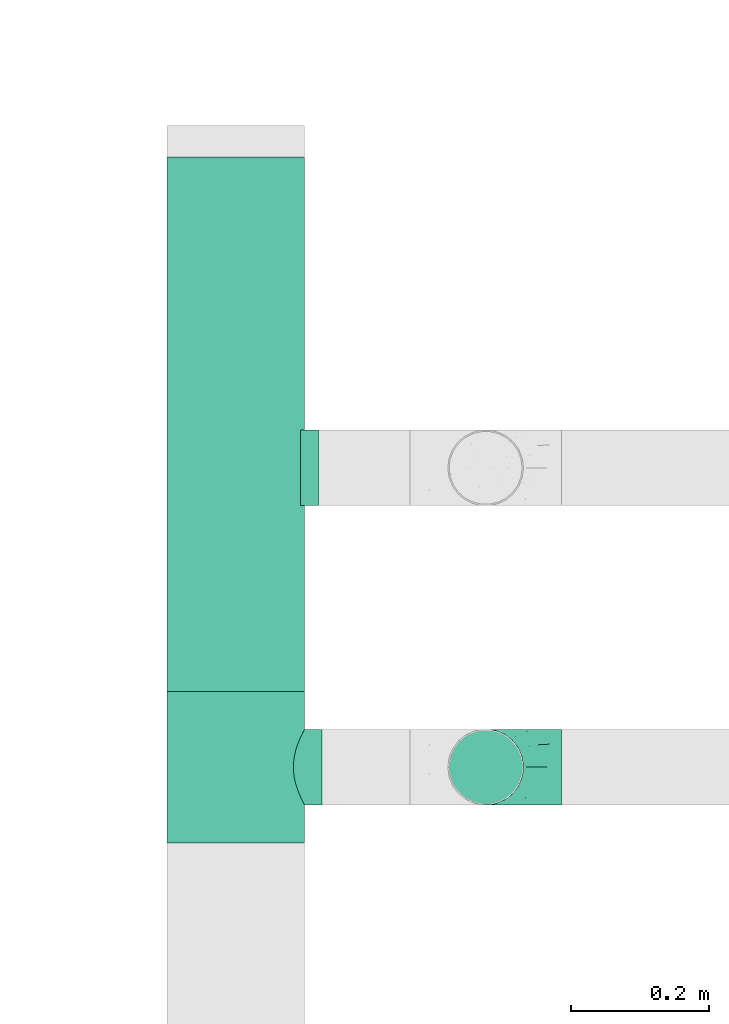
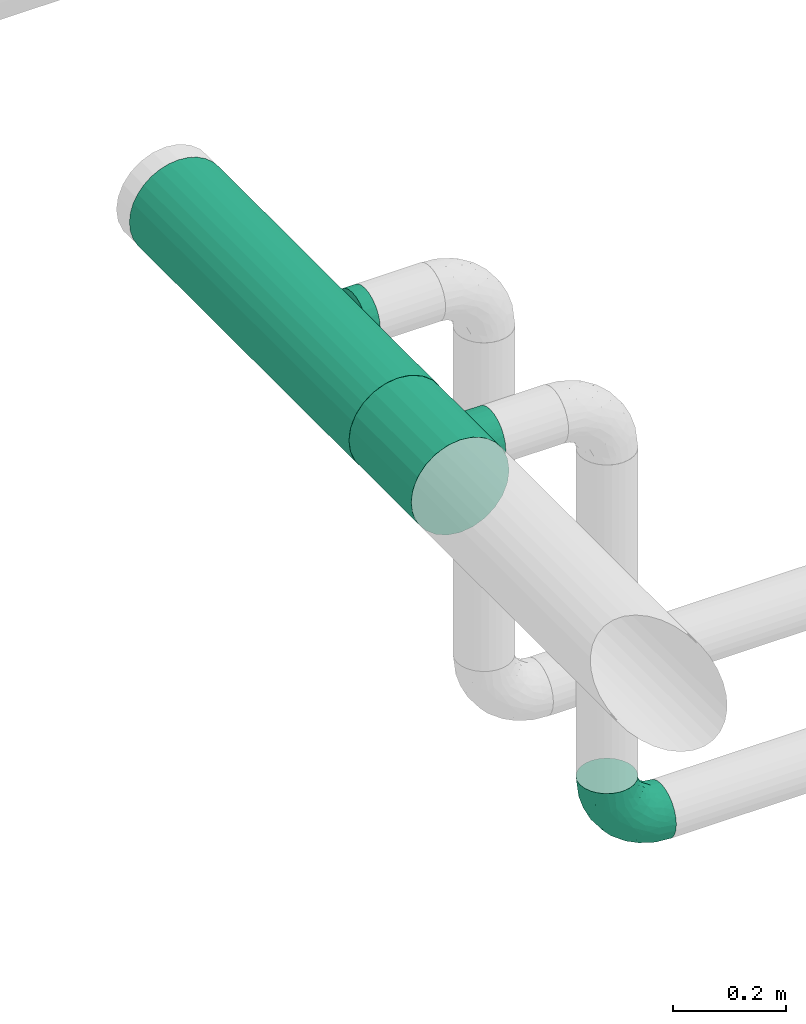
# One storey, part 68 of 91: 3 flow fittings, 1 flow segment.
"""IFC2X3 building model written with IfcOpenShell, lengths in millimetres."""

from ifc_helpers import new_model, entity, si_unit, converted_unit, derived_unit, direction, frame, origin_with_axes, origin_2d_with_axis, place, context, subcontext, project, spatial, hollow_circle, extrude, open_shell, surface_model, source, transform, mapped, material, layer, layer_set, layer_usage, type_object, element, save


model = new_model("IFC2X3")

# Units and contexts
model_context = context("Model", 3, precision=1e-05, world=origin_with_axes(), true_north=direction((0.0, 1.0)))
body_context = subcontext(model_context, "Body", "Model", "MODEL_VIEW")
ifc_project = project(units=[si_unit("AREAUNIT", "SQUARE_METRE"), si_unit("VOLUMEUNIT", "CUBIC_METRE", prefix="DECI"), si_unit("TIMEUNIT", "SECOND"), si_unit("THERMODYNAMICTEMPERATUREUNIT", "DEGREE_CELSIUS"), si_unit("PRESSUREUNIT", "PASCAL"), si_unit("MASSUNIT", "GRAM", prefix="KILO"), si_unit("LENGTHUNIT", "METRE", prefix="MILLI"), si_unit("POWERUNIT", "WATT"), si_unit("ELECTRICCURRENTUNIT", "AMPERE"), si_unit("ELECTRICVOLTAGEUNIT", "VOLT"), derived_unit("VOLUMETRICFLOWRATEUNIT", [(si_unit("VOLUMEUNIT", "CUBIC_METRE", prefix="DECI"), 1), (si_unit("TIMEUNIT", "SECOND"), -1)]), derived_unit("LINEARVELOCITYUNIT", [(si_unit("LENGTHUNIT", "METRE"), 1), (si_unit("TIMEUNIT", "SECOND"), -1)]), derived_unit("MASSDENSITYUNIT", [(si_unit("MASSUNIT", "GRAM", prefix="KILO"), 1), (si_unit("VOLUMEUNIT", "CUBIC_METRE"), -1)]), converted_unit("PLANEANGLEUNIT", "DEGREE", entity("IfcRatioMeasure", 0.01745), si_unit("PLANEANGLEUNIT", "RADIAN"), dimensions=[0, 0, 0, 0, 0, 0, 0])], contexts=[model_context])

# Site, building, storey
site_placement = place(None, origin_with_axes())
site = spatial("IfcSite", under=ifc_project, at=site_placement, CompositionType="ELEMENT")
building_placement = place(site_placement, origin_with_axes())
building = spatial("IfcBuilding", under=site, at=building_placement, Name="mc-building", CompositionType="ELEMENT")
storey_placement = place(building_placement, frame((0.0, 0.0, 8700.0), z_axis=(0.0, 0.0, 1.0), x_axis=(1.0, 0.0, 0.0)))
storey = spatial("IfcBuildingStorey", under=building, at=storey_placement, CompositionType="ELEMENT", Elevation=8700.0)

# Flow fittings
duct_fitting_type_1 = type_object("IfcDuctFittingType", Name="BU", PredefinedType="BEND")
shared_shape_1 = source(origin_with_axes(), body_context, "Body", "SurfaceModel", [
    surface_model("IfcShellBasedSurfaceModel", [(-110.0, 0.0, -55.0), (-110.0, -14.23505, -53.12592), (-110.0, 14.23505, -53.12592), (-110.0, 53.12592, 14.23505), (-110.0, 27.5, -47.63139), (-110.0, 38.89087, -38.89087), (-110.0, -55.0, 0.0), (-110.0, -53.12592, 14.23505), (-110.0, -38.89087, -38.89087), (-110.0, -27.5, -47.63139), (-110.0, -53.12592, -14.23505), (-110.0, -47.63139, -27.5), (-110.0, -14.23505, 53.12592), (-110.0, 14.23505, 53.12592), (-110.0, 27.5, 47.63139), (-110.0, -47.63139, 27.5), (-110.0, -38.89087, 38.89087), (-110.0, -27.5, 47.63139), (-110.0, 0.0, 55.0), (-110.0, 55.0, 0.0), (-110.0, 53.12592, -14.23505), (-110.0, 47.63139, -27.5), (-110.0, 47.63139, 27.5), (-110.0, 38.89087, 38.89087), (-14.23505, 110.0, -53.12592), (-55.0, 110.0, 0.0), (0.0, 110.0, -55.0), (-27.5, 110.0, -47.63139), (-38.89087, 110.0, -38.89087), (-47.63139, 110.0, -27.5), (38.89087, 110.0, -38.89087), (53.12592, 110.0, 14.23505), (27.5, 110.0, -47.63139), (14.23505, 110.0, -53.12592), (47.63139, 110.0, -27.5), (53.12592, 110.0, -14.23505), (55.0, 110.0, 0.0), (-53.12592, 110.0, -14.23505), (-53.12592, 110.0, 14.23505), (-47.63139, 110.0, 27.5), (-38.89087, 110.0, 38.89087), (-27.5, 110.0, 47.63139), (0.0, 110.0, 55.0), (-14.23505, 110.0, 53.12592), (38.89087, 110.0, 38.89087), (47.63139, 110.0, 27.5), (27.5, 110.0, 47.63139), (14.23505, 110.0, 53.12592), (-64.21732, 48.68956, 43.63444), (-76.6405, 38.18013, 45.55988), (-60.44912, 32.56953, 51.94617), (-76.00813, 5.38378, 55.0), (-90.15553, 11.94394, 54.09138), (-78.5998, 26.77405, 50.81338), (-70.18771, 18.55163, 54.03432), (-75.55424, 54.2118, 32.41257), (-93.27622, 45.77614, 33.48188), (-96.12334, 22.13664, 50.81337), (-21.00813, 45.34362, 55.0), (-18.36258, 70.48427, 54.04484), (-32.04182, 59.64019, 52.24446), (-63.88653, 74.77858, 17.99134), (-74.66383, 63.08407, 19.92123), (-63.60674, 66.07878, 29.97482), (-99.597, 52.72185, 18.52927), (-93.11138, 56.59448, 10.50359), (-98.21577, 57.34403, 0.0), (-53.42855, 92.60092, 21.04759), (-88.54852, 54.8376, 21.04759), (-11.86161, 90.23965, 54.10313), (-5.38378, 76.00813, 55.0), (-57.34403, 98.21577, 0.0), (-56.64619, 93.12774, 10.22088), (-45.34362, 21.00813, 55.0), (-44.60838, 44.60838, 52.13415), (-92.68484, 35.46673, 43.63443), (-22.25266, 95.40765, 50.81337), (-35.97783, 90.61597, 43.63443), (-43.70931, 69.58671, 44.47149), (-27.23711, 77.39884, 50.81337), (-57.2828, 79.3123, 24.9774), (-58.67786, 84.31125, 16.04456), (-82.93277, 60.36161, 12.91784), (-49.88337, 54.51816, 47.224), (-74.57753, 66.83759, 9.55742), (-45.35812, 94.97281, 33.48188), (-59.18663, 88.95241, 0.0), (-51.517, 78.6292, 33.48188), (-65.14788, 80.03077, 0.0), (-56.45322, 62.06476, 39.63545), (-88.95241, 59.18663, 0.0), (-71.10913, 71.10913, 0.0), (-80.03077, 65.14788, 0.0), (-94.9309, 45.36788, -33.48188), (-93.11358, 56.60141, -10.46614), (-99.64997, 52.79499, -18.30015), (-90.20425, 36.08686, -43.63443), (-79.99933, 46.56772, -37.92748), (-76.00813, 5.38378, -55.0), (-72.75364, 19.68651, -53.60527), (-45.34362, 21.00813, -55.0), (-21.91957, 65.12078, -53.85897), (-5.38378, 76.00813, -55.0), (-21.00813, 45.34362, -55.0), (-35.41876, 92.89265, -43.63443), (-91.10309, 11.02766, -54.21832), (-45.77614, 93.27622, -33.48188), (-90.50474, 23.21022, -50.81337), (-70.92854, 33.31794, -49.51754), (-78.52933, 63.35627, -11.73997), (-24.91508, 84.05606, -50.81337), (-88.78941, 54.74452, -21.04759), (-69.59921, 57.34866, -33.48187), (-73.36422, 62.46673, -22.94182), (-63.49062, 67.59111, -28.46929), (-56.59448, 93.11138, -10.50359), (-54.8376, 88.54852, -21.04759), (-54.10679, 75.85581, -32.31867), (-57.75956, 31.09612, -52.80882), (-52.72185, 99.597, -18.52927), (-12.62913, 89.46304, -53.99097), (-34.46825, 66.46123, -50.04329), (-43.9837, 43.9837, -52.42279), (-65.78527, 72.58348, -17.68796), (-70.34468, 43.65295, -44.21951), (-57.47001, 51.99467, -44.91465), (-60.72547, 82.29174, -12.88567), (-42.34915, 74.24548, -43.63444), (-57.25194, 63.5016, -38.08211), (-80.95344, 53.56991, -29.32027), (-52.32891, 4.55257, -54.0482), (32.52942, 47.13398, -30.48571), (14.88266, 20.92917, -33.7947), (14.95561, 36.05775, -42.26543), (30.24048, 70.09027, -41.7461), (19.3559, 65.35825, -48.00507), (-70.35075, -46.44478, -19.5952), (-47.13398, -32.52942, -30.48571), (-28.49299, -30.5778, -16.4009), (-4.55257, 52.32891, -54.0482), (-22.4954, 22.4954, -53.25347), (-75.47368, -11.22546, -52.60718), (-81.32209, -51.5606, -9.98467), (-80.81763, -41.84862, -32.14655), (-70.09027, -30.24048, -41.7461), (-36.05774, -14.95561, -42.26543), (-9.15831, -10.852, -27.8997), (-65.35825, -19.3559, -48.00507), (11.22546, 75.47368, -52.60718), (3.94376, 43.9333, -50.53315), (-13.39742, 13.39743, -48.13058), (-43.9333, -3.94376, -50.53315), (49.37776, 67.29486, 0.0), (41.8609, 47.82256, -9.92641), (50.20582, 74.51695, -9.9731), (18.93131, 11.7156, -17.56239), (-27.5, -32.89419, 0.0), (-1.23348, -12.25375, -12.18106), (41.84862, 80.81763, -32.14655), (35.70604, 41.31408, -20.38235), (46.44478, 70.35075, -19.5952), (32.89419, 27.5, 0.0), (6.67262, -6.67262, 0.0), (-67.29486, -49.37776, 0.0), (-50.36265, -42.95545, -9.51562), (-5.47251, 5.47251, -39.92906), (-70.35075, -46.44478, 19.5952), (-74.51695, -50.20582, 9.9731), (-41.31407, -35.70604, 20.38235), (-47.13398, -32.52942, 30.48571), (-80.81763, -41.84862, 32.14655), (-4.55257, 52.32891, 54.0482), (11.22546, 75.47368, 52.60718), (-43.9333, -3.94376, 50.53315), (-65.35825, -19.3559, 48.00507), (-36.05774, -14.95561, 42.26543), (-70.09027, -30.24048, 41.7461), (-11.7156, -18.93131, 17.56239), (30.5778, 28.49299, 16.4009), (12.25375, 1.23348, 12.18106), (51.5606, 81.32209, 9.98467), (42.95545, 50.36265, 9.51562), (-75.47368, -11.22546, 52.60718), (-52.32891, 4.55257, 54.0482), (3.94376, 43.9333, 50.53315), (-22.4954, 22.4954, 53.25347), (-13.39742, 13.39743, 48.13058), (10.852, 9.15831, 27.8997), (-20.92916, -14.88266, 33.79469), (-47.82256, -41.8609, 9.92641), (32.52942, 47.13398, 30.48571), (46.44478, 70.35075, 19.5952), (41.84862, 80.81763, 32.14655), (30.24048, 70.09027, 41.7461), (19.3559, 65.35825, 48.00507), (14.95561, 36.05775, 42.26543), (-5.47251, 5.47251, 39.92906)], [open_shell([[[0, 1, 2]], [[2, 3, 4]], [[4, 3, 5]], [[2, 6, 7]], [[8, 6, 9]], [[1, 9, 6]], [[10, 6, 11]], [[8, 11, 6]], [[6, 2, 1]], [[12, 13, 14]], [[15, 2, 7]], [[16, 17, 2]], [[2, 17, 12]], [[12, 18, 13]], [[19, 20, 3]], [[5, 3, 21]], [[20, 21, 3]], [[22, 3, 2]], [[23, 22, 2]], [[12, 14, 2]], [[2, 14, 23]], [[15, 16, 2]], [[24, 25, 26]], [[27, 25, 24]], [[25, 28, 29]], [[28, 25, 27]], [[30, 26, 31]], [[26, 30, 32]], [[32, 33, 26]], [[34, 31, 35]], [[31, 34, 30]], [[35, 31, 36]], [[29, 37, 25]], [[38, 39, 26]], [[39, 40, 26]], [[41, 42, 40]], [[42, 26, 40]], [[42, 41, 43]], [[26, 44, 45]], [[31, 26, 45]], [[26, 46, 44]], [[47, 46, 26]], [[42, 47, 26]], [[25, 38, 26]], [[48, 49, 50]], [[18, 51, 52]], [[53, 54, 50]], [[55, 56, 49]], [[56, 22, 23]], [[13, 57, 14]], [[58, 59, 60]], [[61, 62, 63]], [[3, 64, 65]], [[53, 52, 54]], [[3, 65, 66]], [[67, 39, 38]], [[56, 68, 64]], [[65, 64, 68]], [[69, 59, 70]], [[38, 71, 72]], [[73, 58, 74]], [[75, 49, 56]], [[76, 69, 43]], [[53, 57, 52]], [[77, 78, 79]], [[41, 76, 43]], [[43, 69, 42]], [[55, 68, 56]], [[23, 14, 75]], [[76, 77, 79]], [[80, 67, 81]], [[62, 82, 68]], [[60, 78, 83]], [[62, 84, 82]], [[85, 77, 40]], [[81, 67, 72]], [[86, 72, 71]], [[87, 85, 67]], [[61, 81, 88]], [[77, 41, 40]], [[78, 77, 87]], [[23, 75, 56]], [[83, 89, 48]], [[85, 40, 39]], [[62, 68, 55]], [[89, 87, 63]], [[83, 48, 50]], [[57, 75, 14]], [[49, 75, 53]], [[67, 85, 39]], [[87, 77, 85]], [[63, 62, 55]], [[89, 55, 48]], [[80, 63, 87]], [[66, 65, 90]], [[66, 19, 3]], [[84, 91, 92]], [[92, 90, 82]], [[65, 82, 90]], [[61, 84, 62]], [[92, 82, 84]], [[68, 82, 65]], [[3, 22, 64]], [[56, 64, 22]], [[38, 25, 71]], [[81, 72, 86]], [[38, 72, 67]], [[91, 61, 88]], [[80, 81, 61]], [[63, 80, 61]], [[67, 80, 87]], [[77, 76, 41]], [[79, 59, 69]], [[79, 69, 76]], [[42, 69, 70]], [[60, 59, 79]], [[58, 70, 59]], [[78, 60, 79]], [[58, 60, 74]], [[52, 57, 13]], [[75, 57, 53]], [[18, 52, 13]], [[52, 51, 54]], [[51, 73, 54]], [[50, 73, 74]], [[73, 50, 54]], [[50, 74, 83]], [[60, 83, 74]], [[89, 83, 78]], [[87, 89, 78]], [[55, 89, 63]], [[50, 49, 53]], [[55, 49, 48]], [[81, 86, 88]], [[91, 84, 61]], [[5, 21, 93]], [[90, 94, 66]], [[20, 94, 95]], [[96, 93, 97]], [[98, 99, 100]], [[96, 4, 5]], [[101, 102, 103]], [[28, 27, 104]], [[2, 105, 0]], [[104, 106, 28]], [[99, 105, 107]], [[108, 107, 96]], [[90, 109, 94]], [[107, 2, 4]], [[20, 66, 94]], [[27, 24, 110]], [[109, 111, 94]], [[112, 113, 114]], [[37, 115, 71]], [[116, 106, 117]], [[99, 118, 100]], [[116, 115, 119]], [[37, 119, 115]], [[24, 120, 110]], [[121, 110, 101]], [[119, 106, 116]], [[101, 110, 120]], [[122, 103, 100]], [[117, 123, 116]], [[124, 125, 108]], [[115, 116, 126]], [[106, 29, 28]], [[26, 102, 120]], [[127, 104, 110]], [[97, 124, 96]], [[125, 122, 118]], [[128, 127, 125]], [[96, 5, 93]], [[115, 126, 86]], [[117, 106, 127]], [[111, 113, 129]], [[95, 93, 21]], [[97, 129, 112]], [[110, 104, 27]], [[106, 104, 127]], [[96, 107, 4]], [[99, 107, 108]], [[99, 108, 118]], [[105, 99, 98]], [[112, 114, 128]], [[121, 125, 127]], [[20, 19, 66]], [[109, 90, 92]], [[94, 111, 95]], [[91, 123, 109]], [[129, 113, 112]], [[93, 95, 111]], [[21, 20, 95]], [[71, 115, 86]], [[71, 25, 37]], [[123, 91, 88]], [[126, 116, 123]], [[123, 88, 126]], [[86, 126, 88]], [[37, 29, 119]], [[106, 119, 29]], [[129, 93, 111]], [[124, 112, 125]], [[0, 105, 98]], [[107, 105, 2]], [[125, 118, 108]], [[100, 118, 122]], [[93, 129, 97]], [[113, 111, 109]], [[109, 123, 113]], [[114, 123, 117]], [[123, 114, 113]], [[128, 114, 117]], [[127, 128, 117]], [[112, 128, 125]], [[103, 122, 101]], [[110, 121, 127]], [[101, 122, 121]], [[125, 121, 122]], [[26, 120, 24]], [[101, 120, 102]], [[96, 124, 108]], [[92, 91, 109]], [[112, 124, 97]], [[100, 130, 98]], [[131, 132, 133]], [[32, 134, 135]], [[136, 137, 138]], [[139, 140, 103]], [[98, 141, 0]], [[142, 10, 136]], [[143, 144, 137]], [[6, 10, 142]], [[137, 145, 146]], [[144, 147, 145]], [[143, 136, 11]], [[11, 136, 10]], [[8, 143, 11]], [[148, 149, 139]], [[8, 9, 144]], [[9, 1, 147]], [[130, 141, 98]], [[103, 140, 100]], [[148, 135, 149]], [[150, 151, 140]], [[152, 153, 154]], [[130, 140, 151]], [[148, 26, 33]], [[147, 1, 141]], [[155, 146, 132]], [[156, 138, 157]], [[134, 30, 158]], [[150, 140, 149]], [[158, 30, 34]], [[30, 134, 32]], [[153, 159, 160]], [[131, 160, 159]], [[144, 145, 137]], [[36, 152, 154]], [[146, 138, 137]], [[155, 161, 162]], [[158, 160, 131]], [[133, 149, 135]], [[156, 163, 164]], [[163, 142, 164]], [[139, 103, 102]], [[153, 152, 161]], [[34, 35, 160]], [[162, 157, 155]], [[132, 165, 133]], [[157, 146, 155]], [[140, 130, 100]], [[141, 130, 151]], [[141, 151, 147]], [[141, 1, 0]], [[102, 26, 148]], [[140, 139, 149]], [[102, 148, 139]], [[135, 33, 32]], [[151, 150, 145]], [[9, 147, 144]], [[151, 145, 147]], [[145, 165, 146]], [[135, 148, 33]], [[133, 135, 134]], [[131, 133, 134]], [[133, 165, 150]], [[133, 150, 149]], [[145, 150, 165]], [[132, 131, 159]], [[146, 165, 132]], [[160, 158, 34]], [[134, 158, 131]], [[144, 143, 8]], [[136, 143, 137]], [[155, 153, 161]], [[154, 153, 160]], [[153, 155, 159]], [[132, 159, 155]], [[160, 35, 154]], [[36, 154, 35]], [[164, 136, 138]], [[6, 142, 163]], [[136, 164, 142]], [[156, 164, 138]], [[156, 157, 162]], [[146, 157, 138]], [[15, 7, 166]], [[6, 163, 167]], [[168, 169, 166]], [[166, 169, 170]], [[171, 172, 70]], [[173, 174, 175]], [[17, 176, 174]], [[177, 156, 162]], [[176, 16, 170]], [[170, 16, 15]], [[161, 178, 179]], [[152, 180, 181]], [[182, 173, 183]], [[18, 12, 182]], [[184, 185, 186]], [[183, 185, 73]], [[183, 73, 51]], [[177, 187, 188]], [[189, 168, 166]], [[187, 178, 190]], [[16, 176, 17]], [[161, 152, 181]], [[45, 191, 31]], [[45, 44, 192]], [[192, 191, 45]], [[180, 36, 31]], [[193, 194, 195]], [[46, 47, 194]], [[193, 195, 190]], [[193, 44, 46]], [[172, 42, 70]], [[185, 58, 73]], [[189, 163, 156]], [[163, 189, 167]], [[70, 58, 171]], [[184, 171, 185]], [[169, 188, 175]], [[180, 31, 191]], [[192, 193, 190]], [[191, 190, 178]], [[182, 174, 173]], [[194, 47, 172]], [[190, 195, 187]], [[186, 185, 173]], [[162, 179, 177]], [[188, 196, 175]], [[179, 187, 177]], [[185, 171, 58]], [[172, 171, 184]], [[172, 184, 194]], [[172, 47, 42]], [[51, 18, 182]], [[185, 183, 173]], [[51, 182, 183]], [[174, 12, 17]], [[184, 186, 195]], [[46, 194, 193]], [[184, 195, 194]], [[195, 196, 187]], [[174, 182, 12]], [[175, 174, 176]], [[169, 175, 176]], [[175, 196, 186]], [[175, 186, 173]], [[195, 186, 196]], [[188, 169, 168]], [[187, 196, 188]], [[166, 170, 15]], [[176, 170, 169]], [[193, 192, 44]], [[191, 192, 190]], [[177, 189, 156]], [[167, 189, 166]], [[189, 177, 168]], [[188, 168, 177]], [[166, 7, 167]], [[6, 167, 7]], [[181, 191, 178]], [[36, 180, 152]], [[191, 181, 180]], [[161, 181, 178]], [[161, 179, 162]], [[187, 179, 178]]])]),
])
flow_fitting_1_placement = place(storey_placement, frame((33727.76981, 7384.97206, 415.0), z_axis=(0.0, 1.0, 0.0), x_axis=(-1.0, 0.0, 0.0)))
element("IfcFlowFitting", 1, at=flow_fitting_1_placement, inside=storey, type_object=duct_fitting_type_1, Name="BU", context=body_context, shape_type="MappedRepresentation", body=[
    mapped(shared_shape_1, transform((0.0, 0.0, 0.0), scale=1.0)),
])
duct_fitting_type_2 = type_object("IfcDuctFittingType", Name="CC", PredefinedType="CONNECTOR")
shared_shape_2 = source(origin_with_axes(), body_context, "Body", "SurfaceModel", [
    surface_model("IfcShellBasedSurfaceModel", [(-6.096, -38.89087, -38.89087), (-6.096, -55.0, 0.0), (-6.096, -27.5, -47.63139), (-6.096, 47.63139, -27.5), (-6.096, 53.12592, 14.23505), (-6.096, 53.12592, -14.23505), (-6.096, 55.0, 0.0), (-6.096, -53.12592, -14.23505), (-6.096, -47.63139, -27.5), (20.0, 38.89087, -38.89087), (20.0, 55.0, 0.0), (20.0, 27.5, -47.63139), (20.0, 53.12592, -14.23505), (20.0, 47.63139, -27.5), (20.0, -47.63139, -27.5), (20.0, -53.12592, 14.23505), (20.0, -53.12592, -14.23505), (20.0, -55.0, 0.0), (-6.096, 0.0, -55.0), (-6.096, -14.23505, -53.12592), (-6.096, 14.23505, -53.12592), (-6.096, 27.5, -47.63139), (-6.096, 38.89087, -38.89087), (-6.096, -53.12592, 14.23505), (-6.096, 47.63139, 27.5), (-6.096, 38.89087, 38.89087), (-6.096, -14.23505, 53.12592), (-6.096, 27.5, 47.63139), (-6.096, 14.23505, 53.12592), (-6.096, -47.63139, 27.5), (-6.096, -38.89087, 38.89087), (-6.096, -27.5, 47.63139), (-6.096, 0.0, 55.0), (0.0, 0.0, 55.0), (0.0, 14.23505, 53.12592), (0.0, 27.5, 47.63139), (0.0, 38.89087, 38.89087), (0.0, 47.63139, 27.5), (0.0, 53.12592, 14.23505), (0.0, 55.0, 0.0), (0.0, 53.12592, -14.23505), (0.0, 47.63139, -27.5), (0.0, 38.89087, -38.89087), (0.0, 27.5, -47.63139), (0.0, 14.23505, -53.12592), (0.0, 0.0, -55.0), (0.0, -14.23505, -53.12592), (0.0, -27.5, -47.63139), (0.0, -38.89087, -38.89087), (0.0, -47.63139, -27.5), (0.0, -53.12592, -14.23505), (0.0, -55.0, 0.0), (0.0, -53.12592, 14.23505), (0.0, -47.63139, 27.5), (0.0, -38.89087, 38.89087), (0.0, -27.5, 47.63139), (0.0, -14.23505, 53.12592), (20.0, 0.0, -55.0), (20.0, 14.23505, -53.12592), (20.0, -38.89087, -38.89087), (20.0, -27.5, -47.63139), (20.0, -14.23505, -53.12592), (20.0, 53.12592, 14.23505), (20.0, 47.63139, 27.5), (20.0, 38.89087, 38.89087), (20.0, 0.0, 55.0), (20.0, 27.5, 47.63139), (20.0, 14.23505, 53.12592), (20.0, -38.89087, 38.89087), (20.0, -47.63139, 27.5), (20.0, -14.23505, 53.12592), (20.0, -27.5, 47.63139)], [open_shell([[[0, 1, 2]], [[3, 4, 5]], [[6, 5, 4]], [[7, 1, 8]], [[9, 10, 11]], [[12, 10, 13]], [[14, 15, 16]], [[17, 16, 15]], [[18, 19, 20]], [[20, 4, 21]], [[3, 22, 4]], [[21, 4, 22]], [[20, 1, 23]], [[19, 2, 1]], [[0, 8, 1]], [[1, 20, 19]], [[20, 24, 4]], [[25, 24, 20]], [[26, 27, 20]], [[27, 25, 20]], [[26, 28, 27]], [[20, 29, 30]], [[29, 20, 23]], [[30, 31, 20]], [[20, 31, 26]], [[26, 32, 28]], [[32, 33, 34]], [[28, 34, 35]], [[32, 34, 28]], [[27, 36, 25]], [[27, 28, 35]], [[36, 27, 35]], [[24, 37, 38]], [[4, 38, 39]], [[25, 37, 24]], [[4, 24, 38]], [[6, 4, 39]], [[37, 25, 36]], [[6, 39, 40]], [[5, 40, 41]], [[6, 40, 5]], [[3, 42, 22]], [[3, 5, 41]], [[42, 3, 41]], [[21, 43, 44]], [[20, 44, 45]], [[22, 43, 21]], [[20, 21, 44]], [[18, 20, 45]], [[43, 22, 42]], [[18, 45, 46]], [[19, 46, 47]], [[18, 46, 19]], [[2, 48, 0]], [[2, 19, 47]], [[48, 2, 47]], [[8, 49, 50]], [[7, 50, 51]], [[0, 49, 8]], [[7, 8, 50]], [[1, 7, 51]], [[49, 0, 48]], [[1, 51, 52]], [[23, 52, 53]], [[1, 52, 23]], [[29, 54, 30]], [[29, 23, 53]], [[54, 29, 53]], [[31, 55, 56]], [[26, 56, 33]], [[30, 55, 31]], [[26, 31, 56]], [[32, 26, 33]], [[55, 30, 54]], [[10, 57, 58]], [[11, 10, 58]], [[10, 9, 13]], [[59, 57, 15]], [[57, 59, 60]], [[60, 61, 57]], [[59, 15, 14]], [[62, 63, 57]], [[57, 63, 64]], [[65, 64, 66]], [[65, 57, 64]], [[67, 65, 66]], [[68, 69, 57]], [[15, 57, 69]], [[70, 71, 57]], [[71, 68, 57]], [[70, 57, 65]], [[10, 62, 57]], [[33, 65, 67]], [[34, 67, 66]], [[33, 67, 34]], [[35, 64, 36]], [[35, 34, 66]], [[64, 35, 66]], [[37, 63, 62]], [[38, 62, 10]], [[36, 63, 37]], [[38, 37, 62]], [[39, 38, 10]], [[63, 36, 64]], [[39, 10, 12]], [[40, 12, 13]], [[39, 12, 40]], [[41, 9, 42]], [[41, 40, 13]], [[9, 41, 13]], [[43, 11, 58]], [[44, 58, 57]], [[42, 11, 43]], [[44, 43, 58]], [[45, 44, 57]], [[11, 42, 9]], [[45, 57, 61]], [[46, 61, 60]], [[45, 61, 46]], [[47, 59, 48]], [[47, 46, 60]], [[59, 47, 60]], [[49, 14, 16]], [[50, 16, 17]], [[48, 14, 49]], [[50, 49, 16]], [[51, 50, 17]], [[14, 48, 59]], [[51, 17, 15]], [[52, 15, 69]], [[51, 15, 52]], [[53, 68, 54]], [[53, 52, 69]], [[68, 53, 69]], [[55, 71, 70]], [[56, 70, 65]], [[54, 71, 55]], [[56, 55, 70]], [[33, 56, 65]], [[71, 54, 68]], [[65, 57, 66]], [[57, 64, 66]], [[65, 66, 67]], [[69, 15, 57]]])]),
])
flow_fitting_2_placement = place(storey_placement, frame((33464.76981, 7819.73852, 1344.0), z_axis=(0.0, 0.0, -1.0), x_axis=(1.0, 0.0, 0.0)))
element("IfcFlowFitting", 2, at=flow_fitting_2_placement, inside=storey, type_object=duct_fitting_type_2, Name="CC", context=body_context, shape_type="MappedRepresentation", body=[
    mapped(shared_shape_2, transform((0.0, 0.0, 0.0), scale=1.0)),
])
duct_fitting_type_3 = type_object("IfcDuctFittingType", PredefinedType="JUNCTION")
shared_shape_3 = source(origin_with_axes(), body_context, "Body", "SurfaceModel", [
    surface_model("IfcShellBasedSurfaceModel", [(0.0, -125.0, -55.0), (14.23505, -125.0, -53.12592), (-14.23505, -125.0, -53.12592), (-53.12592, -125.0, 14.23505), (-27.5, -125.0, -47.63139), (-47.63139, -125.0, -27.5), (-38.89087, -125.0, -38.89087), (55.0, -125.0, 0.0), (53.12592, -125.0, 14.23505), (38.89087, -125.0, -38.89087), (27.5, -125.0, -47.63139), (53.12592, -125.0, -14.23505), (47.63139, -125.0, -27.5), (-53.12592, -125.0, -14.23505), (-47.63139, -125.0, 27.5), (-38.89087, -125.0, 38.89087), (14.23505, -125.0, 53.12592), (-27.5, -125.0, 47.63139), (-14.23505, -125.0, 53.12592), (47.63139, -125.0, 27.5), (38.89087, -125.0, 38.89087), (27.5, -125.0, 47.63139), (0.0, -125.0, 55.0), (-55.0, -125.0, 0.0), (0.0, -83.51647, 55.0), (-12.46155, -84.44105, 53.56967), (-24.08744, -86.92068, 49.44487), (-34.33571, -90.29918, 42.96579), (-42.88021, -93.88137, 34.44253), (-49.41352, -97.03966, 24.15169), (-53.56772, -99.21945, 12.46996), (-55.0, -100.0, 0.0), (-49.4132, -97.0395, -24.15234), (-42.88214, -93.88226, -34.44012), (-53.56653, -99.21882, -12.47503), (-34.33656, -90.29949, -42.96511), (-24.08533, -86.92009, -49.4459), (-12.45457, -84.44001, -53.57129), (0.0, -83.51647, -55.0), (12.46155, -84.44105, -53.56967), (24.08744, -86.92068, -49.44487), (34.33571, -90.29918, -42.96579), (42.88021, -93.88137, -34.44253), (49.41352, -97.03966, -24.15169), (53.56772, -99.21945, -12.46996), (55.0, -100.0, 0.0), (49.41352, -97.03966, 24.15169), (42.88021, -93.88137, 34.44253), (53.56772, -99.21945, 12.46996), (34.33571, -90.29918, 42.96579), (24.08744, -86.92068, 49.44487), (12.46155, -84.44105, 53.56967), (-110.0, 0.0, -100.0), (-110.0, -25.8819, -96.59259), (-110.0, 25.8819, -96.59259), (-110.0, 96.59259, 25.8819), (-110.0, 50.0, -86.60254), (-110.0, 86.60254, -50.0), (-110.0, 70.71068, -70.71068), (-110.0, -100.0, 0.0), (-110.0, -96.59259, 25.8819), (-110.0, -70.71068, -70.71068), (-110.0, -50.0, -86.60254), (-110.0, -96.59259, -25.8819), (-110.0, -86.60254, -50.0), (-110.0, 96.59259, -25.8819), (-110.0, 86.60254, 50.0), (-110.0, 70.71068, 70.71068), (-110.0, 50.0, 86.60254), (-110.0, 25.8819, 96.59259), (-110.0, 0.0, 100.0), (-110.0, -86.60254, 50.0), (-110.0, -70.71068, 70.71068), (-110.0, -25.8819, 96.59259), (-110.0, -50.0, 86.60254), (-110.0, 100.0, 0.0), (110.0, 25.8819, -96.59259), (110.0, 100.0, 0.0), (110.0, 0.0, -100.0), (110.0, 50.0, -86.60254), (110.0, 86.60254, -50.0), (110.0, 70.71068, -70.71068), (110.0, -70.71068, -70.71068), (110.0, -96.59259, 25.8819), (110.0, -50.0, -86.60254), (110.0, -25.8819, -96.59259), (110.0, -86.60254, -50.0), (110.0, -96.59259, -25.8819), (110.0, -100.0, 0.0), (110.0, 96.59259, -25.8819), (110.0, 86.60254, 50.0), (110.0, 96.59259, 25.8819), (110.0, 50.0, 86.60254), (110.0, 25.8819, 96.59259), (110.0, 70.71068, 70.71068), (110.0, -25.8819, 96.59259), (110.0, -86.60254, 50.0), (110.0, -70.71068, 70.71068), (110.0, -50.0, 86.60254), (110.0, 0.0, 100.0), (-110.0, -98.29629, -12.94095), (110.0, -91.59756, -37.94095), (-110.0, -91.59756, -37.94095), (110.0, -98.29629, -12.94095), (110.0, -98.29629, 12.94095), (110.0, -91.59756, 37.94095), (-110.0, -98.29629, 12.94095), (-110.0, -91.59756, 37.94095)], [open_shell([[[0, 1, 2]], [[2, 3, 4]], [[5, 6, 3]], [[6, 4, 3]], [[2, 7, 8]], [[9, 7, 10]], [[1, 10, 7]], [[11, 7, 12]], [[9, 12, 7]], [[7, 2, 1]], [[5, 3, 13]], [[2, 14, 3]], [[2, 15, 14]], [[2, 16, 17]], [[17, 15, 2]], [[16, 18, 17]], [[2, 8, 19]], [[2, 19, 20]], [[2, 20, 21]], [[16, 2, 21]], [[16, 22, 18]], [[23, 13, 3]], [[22, 24, 25]], [[18, 25, 26]], [[22, 25, 18]], [[17, 27, 15]], [[17, 18, 26]], [[27, 17, 26]], [[28, 29, 14]], [[30, 31, 23]], [[29, 30, 3]], [[15, 28, 14]], [[23, 3, 30]], [[29, 3, 14]], [[28, 15, 27]], [[32, 33, 5]], [[34, 32, 13]], [[31, 34, 23]], [[23, 34, 13]], [[32, 5, 13]], [[33, 6, 5]], [[4, 35, 36]], [[36, 37, 2]], [[38, 0, 37]], [[6, 35, 4]], [[4, 36, 2]], [[37, 0, 2]], [[35, 6, 33]], [[0, 38, 39]], [[1, 39, 40]], [[0, 39, 1]], [[10, 41, 9]], [[10, 1, 40]], [[41, 10, 40]], [[42, 43, 12]], [[44, 45, 7]], [[43, 44, 11]], [[12, 9, 42]], [[11, 12, 43]], [[44, 7, 11]], [[42, 9, 41]], [[46, 47, 19]], [[48, 46, 8]], [[45, 48, 7]], [[7, 48, 8]], [[46, 19, 8]], [[47, 20, 19]], [[21, 49, 50]], [[50, 51, 16]], [[24, 22, 51]], [[21, 20, 49]], [[16, 21, 50]], [[51, 22, 16]], [[49, 20, 47]], [[52, 53, 54]], [[54, 55, 56]], [[57, 58, 55]], [[58, 56, 55]], [[54, 59, 60]], [[61, 59, 62]], [[54, 53, 62]], [[63, 59, 64]], [[61, 64, 59]], [[62, 59, 54]], [[57, 55, 65]], [[66, 55, 54]], [[54, 67, 66]], [[68, 54, 69]], [[68, 67, 54]], [[70, 69, 54]], [[71, 72, 54]], [[54, 60, 71]], [[73, 70, 74]], [[54, 72, 74]], [[74, 70, 54]], [[75, 65, 55]], [[76, 77, 78]], [[79, 77, 76]], [[80, 77, 81]], [[79, 81, 77]], [[82, 78, 83]], [[78, 84, 85]], [[78, 82, 84]], [[86, 83, 87]], [[83, 86, 82]], [[88, 87, 83]], [[77, 80, 89]], [[90, 78, 91]], [[78, 90, 92]], [[93, 78, 92]], [[92, 90, 94]], [[95, 78, 93]], [[78, 96, 83]], [[97, 96, 78]], [[97, 78, 98]], [[95, 98, 78]], [[93, 99, 95]], [[91, 78, 77]], [[69, 99, 93]], [[68, 93, 92]], [[70, 99, 69]], [[69, 93, 68]], [[92, 67, 68]], [[92, 94, 67]], [[55, 90, 91]], [[75, 91, 77]], [[94, 66, 67]], [[94, 90, 66]], [[66, 90, 55]], [[91, 75, 55]], [[89, 80, 57]], [[77, 89, 65]], [[65, 75, 77]], [[57, 65, 89]], [[80, 58, 57]], [[80, 81, 58]], [[54, 79, 76]], [[52, 76, 78]], [[81, 56, 58]], [[81, 79, 56]], [[56, 79, 54]], [[76, 52, 54]], [[85, 53, 78]], [[84, 62, 85]], [[82, 86, 39]], [[34, 59, 100]], [[39, 38, 82]], [[41, 101, 42]], [[84, 82, 61]], [[82, 38, 61]], [[85, 62, 53]], [[53, 52, 78]], [[37, 36, 64]], [[33, 63, 102]], [[64, 61, 37]], [[36, 35, 64]], [[61, 62, 84]], [[61, 38, 37]], [[39, 86, 40]], [[101, 41, 86]], [[41, 40, 86]], [[42, 87, 43]], [[88, 45, 44]], [[87, 103, 43]], [[44, 103, 88]], [[43, 103, 44]], [[64, 35, 102]], [[63, 33, 32]], [[102, 35, 33]], [[100, 63, 32]], [[31, 59, 34]], [[100, 32, 34]], [[101, 87, 42]], [[45, 88, 48]], [[104, 83, 46]], [[46, 83, 47]], [[46, 48, 104]], [[49, 47, 105]], [[105, 96, 49]], [[31, 30, 59]], [[59, 30, 106]], [[60, 28, 107]], [[60, 106, 29]], [[60, 29, 28]], [[27, 71, 107]], [[50, 96, 51]], [[96, 50, 49]], [[51, 96, 97]], [[29, 106, 30]], [[98, 95, 73]], [[74, 97, 98]], [[51, 97, 24]], [[70, 95, 99]], [[71, 25, 72]], [[48, 88, 104]], [[26, 71, 27]], [[71, 26, 25]], [[25, 24, 72]], [[27, 107, 28]], [[24, 97, 72]], [[97, 74, 72]], [[73, 74, 98]], [[95, 70, 73]], [[47, 83, 105]]])]),
])
flow_fitting_3_placement = place(storey_placement, frame((33364.76981, 7384.97206, 1344.0), z_axis=(0.0, 0.0, 1.0), x_axis=(0.0, 1.0, 0.0)))
element("IfcFlowFitting", 3, at=flow_fitting_3_placement, inside=storey, type_object=duct_fitting_type_3, context=body_context, shape_type="MappedRepresentation", body=[
    mapped(shared_shape_3, transform((0.0, 0.0, 0.0), scale=1.0)),
])

# Flow segment
ifc_material = material(Name="FZ1")
ifc_layer = layer(ifc_material, 0.0)
ifc_layer_set = layer_set([ifc_layer], Name="FZ1")
ifc_layer_usage = layer_usage(ifc_layer_set, "AXIS1", "POSITIVE", 0.0)
duct_segment_type = type_object("IfcDuctSegmentType", Name="Safe", PredefinedType="RIGIDSEGMENT")
shared_shape_4 = source(origin_with_axes(), body_context, "Body", "SweptSolid", [
    extrude(hollow_circle(Radius=100.0, WallThickness=2.0, at=origin_2d_with_axis()), frame((0.0, 0.0, 0.0), z_axis=(1.0, 0.0, 0.0), x_axis=(0.0, 1.0, 0.0)), (0.0, 0.0, 1.0), 776.2),
])
flow_segment_placement = place(storey_placement, frame((33364.76981, 7494.97206, 1344.0), z_axis=(0.0, 0.0, 1.0), x_axis=(0.0, 1.0, 0.0)))
element("IfcFlowSegment", 4, at=flow_segment_placement, inside=storey, type_object=duct_segment_type, material=ifc_layer_usage, Name="Safe", context=body_context, shape_type="MappedRepresentation", body=[
    mapped(shared_shape_4, transform((0.0, 0.0, 0.0), scale=1.0)),
])

save(model, "model.ifc")
